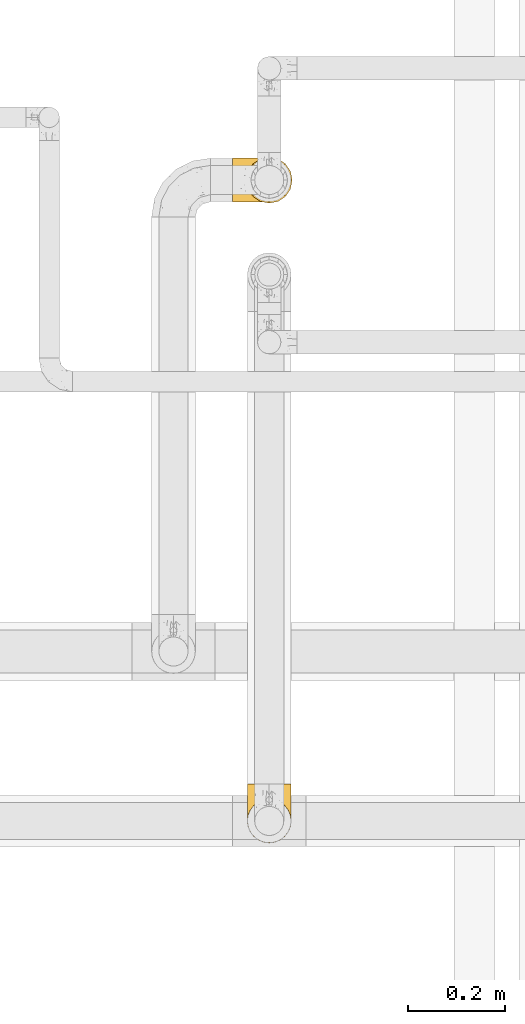
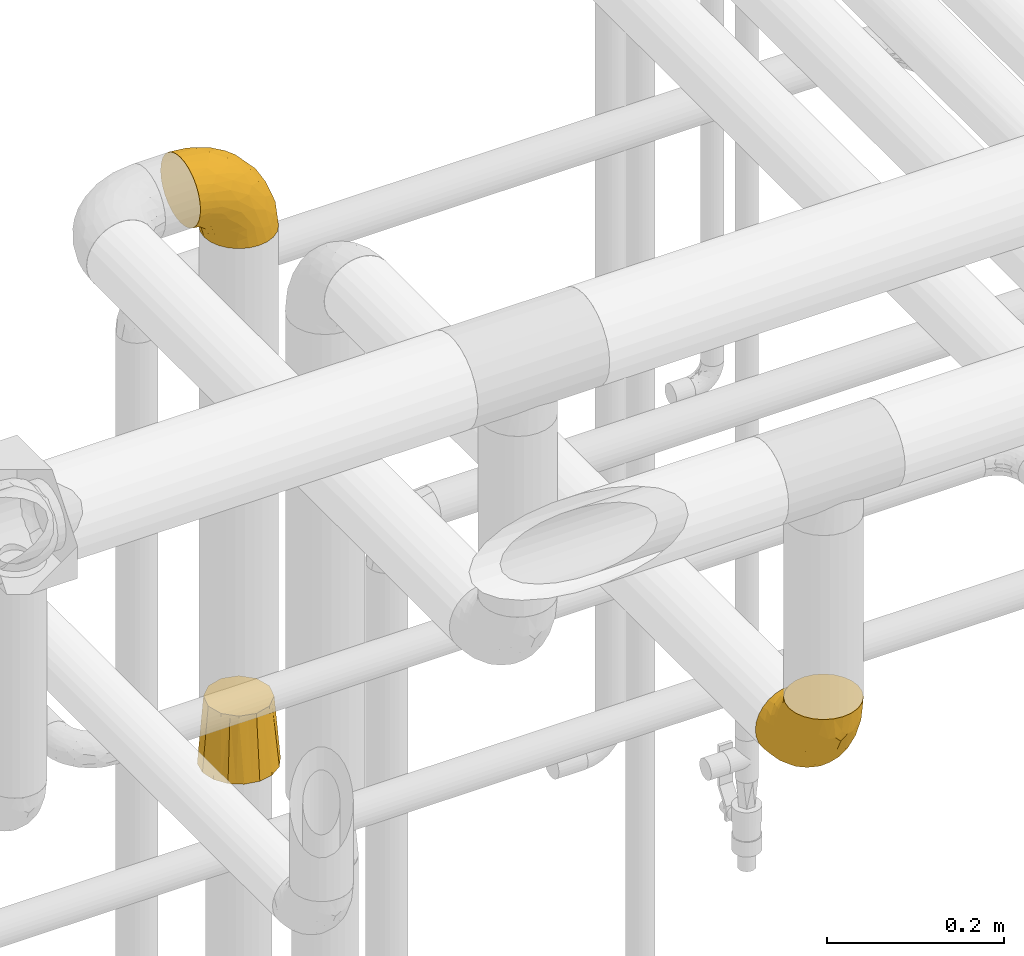
# One storey, part 129 of 827: 3 coverings.
"""IFC2X3 building model written with IfcOpenShell, lengths in millimetres."""

from ifc_helpers import new_model, entity, si_unit, converted_unit, derived_unit, direction, frame, origin, place, context, subcontext, project, spatial, faceted_brep, element, save


model = new_model("IFC2X3")

# Units and contexts
model_context = context("Model", 3, precision=0.01, world=origin(), true_north=direction((6.12303176911189e-17, 1.0)))
body_context = subcontext(model_context, "Body", "Model", "MODEL_VIEW")
ifc_project = project(units=[si_unit("LENGTHUNIT", "METRE", prefix="MILLI"), si_unit("AREAUNIT", "SQUARE_METRE"), si_unit("VOLUMEUNIT", "CUBIC_METRE"), converted_unit("PLANEANGLEUNIT", "DEGREE", entity("IfcRatioMeasure", 0.0174532925199433), si_unit("PLANEANGLEUNIT", "RADIAN"), dimensions=[0, 0, 0, 0, 0, 0, 0]), si_unit("MASSUNIT", "GRAM", prefix="KILO"), derived_unit("MASSDENSITYUNIT", [(si_unit("MASSUNIT", "GRAM", prefix="KILO"), 1), (si_unit("LENGTHUNIT", "METRE"), -3)]), derived_unit("MOMENTOFINERTIAUNIT", [(si_unit("LENGTHUNIT", "METRE"), 4)]), si_unit("TIMEUNIT", "SECOND"), si_unit("FREQUENCYUNIT", "HERTZ"), si_unit("THERMODYNAMICTEMPERATUREUNIT", "DEGREE_CELSIUS"), derived_unit("THERMALTRANSMITTANCEUNIT", [(si_unit("MASSUNIT", "GRAM", prefix="KILO"), 1), (si_unit("THERMODYNAMICTEMPERATUREUNIT", "KELVIN"), -1), (si_unit("TIMEUNIT", "SECOND"), -3)]), derived_unit("VOLUMETRICFLOWRATEUNIT", [(si_unit("LENGTHUNIT", "METRE"), 3), (si_unit("TIMEUNIT", "SECOND"), -1)]), derived_unit("MASSFLOWRATEUNIT", [(si_unit("MASSUNIT", "GRAM", prefix="KILO"), 1), (si_unit("TIMEUNIT", "SECOND"), -1)]), derived_unit("ROTATIONALFREQUENCYUNIT", [(si_unit("TIMEUNIT", "SECOND"), -1)]), si_unit("ELECTRICCURRENTUNIT", "AMPERE"), si_unit("ELECTRICVOLTAGEUNIT", "VOLT"), si_unit("POWERUNIT", "WATT"), si_unit("FORCEUNIT", "NEWTON", prefix="KILO"), si_unit("ILLUMINANCEUNIT", "LUX"), si_unit("LUMINOUSFLUXUNIT", "LUMEN"), si_unit("LUMINOUSINTENSITYUNIT", "CANDELA"), derived_unit("USERDEFINED", [(si_unit("MASSUNIT", "GRAM", prefix="KILO"), -1), (si_unit("LENGTHUNIT", "METRE"), -2), (si_unit("TIMEUNIT", "SECOND"), 3), (si_unit("LUMINOUSFLUXUNIT", "LUMEN"), 1)]), derived_unit("LINEARVELOCITYUNIT", [(si_unit("LENGTHUNIT", "METRE"), 1), (si_unit("TIMEUNIT", "SECOND"), -1)]), si_unit("PRESSUREUNIT", "PASCAL"), derived_unit("USERDEFINED", [(si_unit("LENGTHUNIT", "METRE"), -2), (si_unit("MASSUNIT", "GRAM", prefix="KILO"), 1), (si_unit("TIMEUNIT", "SECOND"), -2)]), derived_unit("LINEARFORCEUNIT", [(si_unit("MASSUNIT", "GRAM", prefix="KILO"), 1), (si_unit("LENGTHUNIT", "METRE"), 1), (si_unit("TIMEUNIT", "SECOND"), -2), (si_unit("LENGTHUNIT", "METRE"), -1)]), derived_unit("PLANARFORCEUNIT", [(si_unit("MASSUNIT", "GRAM", prefix="KILO"), 1), (si_unit("LENGTHUNIT", "METRE"), 1), (si_unit("TIMEUNIT", "SECOND"), -2), (si_unit("LENGTHUNIT", "METRE"), -2)])], contexts=[model_context])

# Site, building, storey
site_placement = place(None, origin())
site = spatial("IfcSite", under=ifc_project, at=site_placement, CompositionType="ELEMENT")
building_placement = place(site_placement, origin())
building = spatial("IfcBuilding", under=site, at=building_placement, CompositionType="ELEMENT")
storey_placement = place(building_placement, frame((0.0, 0.0, 28200.0)))
storey = spatial("IfcBuildingStorey", under=building, at=storey_placement, Name="08", CompositionType="ELEMENT", Elevation=28200.0)

# Coverings
covering_1_placement = place(storey_placement, frame((17844.7, 15675.7, 2322.56)))
element("IfcCovering", 1, at=covering_1_placement, inside=storey, Name=":ADSK_", ObjectType=":ADSK_", PredefinedType="INSULATION", context=body_context, shape_type="Brep", body=[
    faceted_brep([(1.6, 2.73, 87.65), (1.6, 6.07, 97.19), (1.6, 11.45, 105.75), (1.6, 18.6, 112.9), (1.6, 27.16, 118.28), (1.6, 36.7, 121.61), (1.6, 46.75, 122.75), (1.6, 56.8, 121.61), (1.6, 66.34, 118.27), (1.6, 74.9, 112.89), (1.6, 82.05, 105.74), (1.6, 87.43, 97.18), (1.6, 90.76, 87.64), (1.6, 91.9, 77.6), (1.6, 90.76, 67.54), (1.6, 87.42, 58.0), (1.6, 82.04, 49.44), (1.6, 74.89, 42.29), (1.6, 66.33, 36.91), (1.6, 56.79, 33.58), (1.6, 46.75, 32.45), (1.6, 36.69, 33.58), (1.6, 27.15, 36.92), (1.6, 18.59, 42.3), (1.6, 11.44, 49.45), (1.6, 6.06, 58.01), (1.6, 2.73, 67.55), (1.6, 1.6, 77.6), (33.98, 58.43, 1.6), (38.49, 69.32, 1.6), (45.67, 78.67, 1.6), (55.02, 85.85, 1.6), (65.91, 90.36, 1.6), (77.6, 91.9, 1.6), (89.28, 90.36, 1.6), (100.17, 85.85, 1.6), (109.52, 78.67, 1.6), (116.7, 69.32, 1.6), (121.21, 58.43, 1.6), (122.75, 46.75, 1.6), (121.21, 35.06, 1.6), (116.7, 24.17, 1.6), (109.52, 14.82, 1.6), (100.17, 7.64, 1.6), (89.28, 3.13, 1.6), (77.6, 1.6, 1.6), (65.91, 3.13, 1.6), (55.02, 7.64, 1.6), (45.67, 14.82, 1.6), (38.49, 24.17, 1.6), (33.98, 35.06, 1.6), (32.45, 46.75, 1.6), (72.81, 46.75, 99.61), (77.17, 38.29, 95.26), (86.21, 46.75, 86.21), (116.82, 46.75, 39.03), (118.49, 38.96, 30.75), (119.23, 46.75, 23.8), (105.14, 33.86, 60.8), (85.37, 31.42, 85.37), (89.33, 21.63, 73.64), (116.14, 30.84, 31.01), (105.06, 22.16, 49.14), (112.15, 20.56, 23.88), (22.95, 2.29, 82.74), (89.91, 7.18, 43.48), (103.39, 12.6, 29.47), (93.6, 14.0, 56.38), (51.41, 2.81, 72.18), (67.71, 6.65, 72.24), (43.53, 6.11, 87.6), (30.91, 16.62, 107.24), (23.58, 9.76, 101.1), (50.07, 12.46, 95.16), (30.68, 1.6, 71.81), (43.01, 1.6, 63.57), (55.34, 1.6, 55.34), (83.48, 2.46, 23.66), (94.96, 5.91, 20.55), (57.29, 36.97, 107.97), (39.03, 46.75, 116.82), (30.66, 33.09, 117.03), (71.81, 1.6, 30.68), (73.63, 1.6, 21.51), (75.46, 1.6, 12.33), (51.57, 25.62, 106.17), (73.13, 3.14, 52.37), (23.16, 23.92, 114.51), (23.8, 46.75, 119.23), (75.6, 13.58, 78.37), (12.33, 1.6, 75.46), (21.51, 1.6, 73.63), (50.46, 18.5, 101.51), (99.61, 46.75, 72.81), (63.57, 1.6, 43.01), (21.26, 4.96, 92.6), (69.54, 20.84, 91.86), (108.21, 46.75, 55.92), (68.42, 30.52, 99.01), (55.92, 46.75, 108.21), (19.36, 27.29, 32.05), (15.76, 36.89, 30.22), (26.13, 33.6, 23.37), (62.78, 2.54, 28.43), (63.65, 3.27, 16.44), (24.34, 16.85, 37.1), (28.46, 21.91, 28.88), (33.53, 13.5, 33.93), (39.46, 3.96, 50.17), (51.05, 3.52, 40.57), (10.94, 12.17, 47.62), (14.55, 18.93, 39.9), (22.21, 9.34, 47.92), (57.05, 3.12, 34.27), (54.0, 5.67, 24.65), (29.19, 2.51, 62.6), (18.85, 2.53, 66.18), (52.84, 8.35, 11.74), (31.47, 35.39, 13.89), (28.31, 46.75, 17.02), (43.0, 15.1, 15.86), (16.9, 5.27, 57.71), (35.98, 27.43, 9.11), (33.91, 24.89, 18.55), (9.97, 29.71, 34.74), (25.93, 5.07, 54.95), (35.61, 2.88, 57.35), (47.45, 9.69, 22.03), (38.26, 15.51, 24.8), (11.7, 2.27, 69.07), (30.13, 10.03, 42.31), (12.12, 46.75, 29.63), (17.02, 46.75, 28.31), (44.39, 8.83, 30.23), (39.83, 7.16, 40.13), (22.67, 46.75, 22.67), (29.63, 46.75, 12.12), (43.0, 78.39, 15.86), (47.45, 83.8, 22.03), (38.26, 77.97, 24.8), (44.38, 84.66, 30.23), (31.47, 58.1, 13.88), (10.93, 81.31, 47.61), (21.51, 91.9, 73.63), (18.84, 90.96, 66.17), (11.7, 91.22, 69.07), (15.76, 56.59, 30.22), (19.36, 66.18, 32.04), (26.14, 59.87, 23.36), (25.94, 88.42, 54.93), (22.21, 84.13, 47.91), (16.9, 88.22, 57.69), (35.98, 66.06, 9.1), (73.63, 91.9, 21.51), (75.46, 91.9, 12.33), (30.12, 83.44, 42.29), (24.33, 76.62, 37.09), (52.84, 85.14, 11.74), (63.65, 90.22, 16.44), (71.81, 91.9, 30.68), (28.45, 71.55, 28.86), (9.97, 63.77, 34.74), (43.01, 91.9, 63.57), (55.34, 91.9, 55.34), (39.46, 89.53, 50.17), (12.33, 91.9, 75.46), (14.54, 74.55, 39.89), (62.78, 90.95, 28.43), (57.05, 90.37, 34.27), (63.57, 91.9, 43.01), (29.2, 90.98, 62.59), (51.05, 89.97, 40.57), (39.81, 86.32, 40.13), (30.68, 91.9, 71.81), (33.52, 79.97, 33.92), (35.61, 90.61, 57.34), (54.0, 87.82, 24.65), (33.91, 68.6, 18.54), (103.39, 80.89, 29.47), (89.91, 86.31, 43.48), (93.6, 79.49, 56.4), (105.05, 71.33, 49.17), (89.27, 71.88, 73.69), (73.13, 90.35, 52.37), (67.67, 86.85, 72.26), (69.49, 72.67, 91.88), (85.36, 62.08, 85.36), (94.96, 87.58, 20.55), (83.48, 91.03, 23.66), (105.14, 59.62, 60.8), (116.13, 62.65, 31.02), (118.49, 54.53, 30.75), (112.15, 72.93, 23.9), (51.41, 90.68, 72.17), (43.51, 87.39, 87.59), (22.95, 91.2, 82.74), (30.66, 60.41, 117.03), (30.91, 76.88, 107.23), (57.3, 56.53, 107.97), (23.58, 83.74, 101.08), (51.56, 67.88, 106.17), (68.41, 62.99, 99.01), (23.16, 69.58, 114.5), (50.07, 81.04, 95.15), (50.45, 75.0, 101.5), (21.25, 88.53, 92.59), (75.56, 79.93, 78.38), (77.16, 55.21, 95.27)], [[[0, 1, 2, 3, 4, 5, 6, 7, 8, 9, 10, 11, 12, 13, 14, 15, 16, 17, 18, 19, 20, 21, 22, 23, 24, 25, 26, 27]], [[28, 29, 30, 31, 32, 33, 34, 35, 36, 37, 38, 39, 40, 41, 42, 43, 44, 45, 46, 47, 48, 49, 50, 51]], [[52, 53, 54]], [[55, 56, 57]], [[58, 59, 60]], [[61, 62, 63]], [[27, 64, 0]], [[65, 66, 67]], [[41, 40, 61]], [[68, 69, 70]], [[66, 43, 42]], [[63, 42, 41]], [[71, 72, 73]], [[72, 2, 1]], [[68, 74, 75, 76]], [[45, 44, 77]], [[43, 78, 44]], [[79, 80, 81]], [[77, 82, 83, 84, 45]], [[79, 81, 85]], [[71, 2, 72]], [[65, 86, 77]], [[4, 81, 5]], [[66, 65, 78]], [[4, 3, 87]], [[81, 88, 5]], [[63, 66, 42]], [[68, 70, 64]], [[67, 60, 89]], [[71, 3, 2]], [[64, 27, 90, 91, 74]], [[92, 71, 73]], [[40, 57, 56]], [[59, 93, 54]], [[86, 76, 94, 82]], [[1, 0, 95]], [[58, 62, 61]], [[60, 96, 89]], [[85, 81, 87]], [[56, 97, 58]], [[65, 67, 69]], [[87, 81, 4]], [[67, 89, 69]], [[61, 63, 41]], [[95, 72, 1]], [[73, 72, 70]], [[69, 73, 70]], [[73, 89, 96]], [[3, 71, 87]], [[85, 87, 71]], [[58, 61, 56]], [[59, 58, 93]], [[76, 86, 68]], [[69, 89, 73]], [[68, 86, 69]], [[65, 69, 86]], [[68, 64, 74]], [[95, 64, 70]], [[98, 79, 85]], [[79, 52, 99, 80]], [[66, 62, 67]], [[62, 58, 60]], [[62, 60, 67]], [[59, 98, 96]], [[59, 96, 60]], [[96, 85, 92]], [[88, 81, 80]], [[88, 6, 5]], [[66, 63, 62]], [[64, 95, 0]], [[72, 95, 70]], [[77, 44, 78]], [[86, 82, 77]], [[40, 39, 57]], [[96, 98, 85]], [[40, 56, 61]], [[66, 78, 43]], [[77, 78, 65]], [[79, 98, 53]], [[96, 92, 73]], [[85, 71, 92]], [[97, 56, 55]], [[97, 93, 58]], [[53, 98, 59]], [[54, 53, 59]], [[79, 53, 52]], [[100, 101, 102]], [[46, 45, 84, 83]], [[103, 104, 82]], [[82, 104, 83]], [[105, 106, 107]], [[108, 109, 76]], [[110, 111, 112]], [[103, 113, 114]], [[115, 74, 116]], [[48, 47, 117]], [[118, 102, 119]], [[49, 48, 120]], [[74, 91, 116]], [[116, 121, 115]], [[49, 122, 50]], [[123, 106, 102]], [[124, 111, 22]], [[125, 126, 115]], [[23, 22, 111]], [[24, 110, 121]], [[120, 127, 128]], [[90, 26, 129]], [[27, 26, 90]], [[121, 125, 115]], [[24, 121, 25]], [[130, 105, 107]], [[129, 25, 116]], [[21, 20, 131]], [[120, 123, 122]], [[112, 105, 130]], [[50, 118, 51]], [[21, 124, 22]], [[101, 131, 132]], [[117, 120, 48]], [[24, 23, 110]], [[127, 114, 133]], [[75, 108, 76]], [[107, 134, 130]], [[133, 114, 113]], [[129, 116, 91]], [[25, 121, 116]], [[121, 112, 125]], [[75, 74, 115]], [[101, 135, 102]], [[131, 101, 21]], [[101, 100, 124]], [[128, 127, 133]], [[119, 136, 51, 118]], [[104, 47, 46]], [[83, 104, 46]], [[117, 104, 114]], [[101, 124, 21]], [[111, 124, 100]], [[102, 118, 123]], [[133, 134, 107]], [[111, 110, 23]], [[114, 104, 103]], [[94, 76, 109]], [[121, 110, 112]], [[122, 118, 50]], [[134, 109, 108]], [[133, 107, 128]], [[112, 108, 125]], [[126, 125, 108]], [[108, 75, 126]], [[75, 115, 126]], [[109, 134, 133]], [[130, 108, 112]], [[108, 130, 134]], [[105, 112, 111]], [[111, 100, 105]], [[106, 105, 100]], [[102, 106, 100]], [[128, 106, 123]], [[90, 129, 91]], [[25, 129, 26]], [[104, 117, 47]], [[117, 114, 127]], [[82, 94, 103]], [[113, 94, 109]], [[94, 113, 103]], [[133, 113, 109]], [[106, 128, 107]], [[123, 120, 128]], [[120, 122, 49]], [[118, 122, 123]], [[135, 101, 132]], [[135, 119, 102]], [[117, 127, 120]], [[30, 29, 137]], [[138, 139, 140]], [[51, 136, 119, 141]], [[142, 17, 16]], [[143, 144, 145]], [[146, 147, 148]], [[149, 150, 151]], [[152, 29, 28]], [[33, 32, 153, 154]], [[150, 155, 156]], [[157, 31, 30]], [[153, 158, 159]], [[29, 152, 137]], [[148, 141, 119]], [[156, 160, 147]], [[148, 135, 146]], [[137, 138, 157]], [[19, 161, 146]], [[162, 163, 164]], [[14, 13, 165]], [[153, 32, 158]], [[147, 161, 166]], [[18, 17, 166]], [[167, 168, 169]], [[166, 150, 156]], [[151, 150, 142]], [[151, 170, 149]], [[151, 16, 15]], [[171, 140, 172]], [[165, 143, 145]], [[173, 170, 144]], [[142, 166, 17]], [[19, 131, 20]], [[144, 170, 151]], [[18, 161, 19]], [[173, 144, 143]], [[140, 139, 174]], [[171, 164, 163]], [[164, 172, 155]], [[151, 15, 144]], [[145, 15, 14]], [[173, 162, 170]], [[149, 175, 164]], [[19, 146, 131]], [[132, 131, 146]], [[160, 148, 147]], [[159, 158, 167]], [[135, 132, 146]], [[158, 32, 31]], [[157, 158, 31]], [[167, 158, 176]], [[166, 161, 18]], [[146, 161, 147]], [[148, 177, 141]], [[171, 168, 140]], [[171, 163, 169]], [[151, 142, 16]], [[166, 142, 150]], [[152, 141, 177]], [[51, 141, 28]], [[138, 140, 176]], [[172, 140, 174]], [[175, 149, 170]], [[164, 150, 149]], [[170, 162, 175]], [[162, 164, 175]], [[155, 172, 174]], [[171, 172, 164]], [[155, 174, 156]], [[164, 155, 150]], [[160, 156, 174]], [[147, 166, 156]], [[139, 160, 174]], [[148, 160, 177]], [[15, 145, 144]], [[165, 145, 14]], [[137, 157, 30]], [[158, 157, 176]], [[168, 167, 176]], [[169, 159, 167]], [[140, 168, 176]], [[169, 168, 171]], [[137, 177, 139]], [[160, 139, 177]], [[141, 152, 28]], [[137, 152, 177]], [[148, 119, 135]], [[157, 138, 176]], [[139, 138, 137]], [[178, 179, 180]], [[181, 180, 182]], [[179, 183, 184]], [[185, 186, 182]], [[187, 188, 179]], [[188, 33, 154, 153, 159]], [[181, 189, 190]], [[35, 34, 187]], [[191, 38, 190]], [[192, 178, 181]], [[179, 184, 180]], [[192, 190, 37]], [[37, 190, 38]], [[36, 35, 178]], [[54, 93, 186]], [[35, 187, 178]], [[193, 194, 184]], [[195, 173, 143, 165, 13]], [[195, 193, 173]], [[193, 163, 162, 173]], [[13, 12, 195]], [[8, 7, 196]], [[9, 197, 10]], [[198, 80, 99, 52]], [[196, 7, 88]], [[197, 199, 10]], [[182, 189, 181]], [[200, 198, 201]], [[200, 196, 198]], [[9, 8, 202]], [[194, 199, 203]], [[192, 37, 36]], [[80, 196, 88]], [[183, 159, 169, 163]], [[188, 34, 33]], [[202, 200, 197]], [[185, 203, 204]], [[202, 8, 196]], [[10, 199, 11]], [[12, 11, 205]], [[38, 191, 57]], [[189, 97, 191]], [[203, 199, 197]], [[205, 199, 194]], [[204, 203, 197]], [[184, 203, 206]], [[200, 202, 196]], [[197, 9, 202]], [[207, 54, 186]], [[97, 55, 191]], [[194, 203, 184]], [[183, 163, 193]], [[184, 206, 180]], [[183, 193, 184]], [[205, 195, 12]], [[193, 195, 194]], [[80, 198, 196]], [[207, 186, 201]], [[182, 180, 206]], [[181, 178, 180]], [[185, 182, 206]], [[182, 186, 189]], [[203, 185, 206]], [[185, 200, 201]], [[7, 6, 88]], [[178, 192, 36]], [[190, 192, 181]], [[199, 205, 11]], [[195, 205, 194]], [[159, 183, 188]], [[179, 188, 183]], [[57, 191, 55]], [[57, 39, 38]], [[189, 191, 190]], [[188, 187, 34]], [[178, 187, 179]], [[186, 93, 189]], [[197, 200, 204]], [[185, 204, 200]], [[189, 93, 97]], [[207, 198, 52]], [[185, 201, 186]], [[198, 207, 201]], [[54, 207, 52]]]),
])
covering_2_placement = place(storey_placement, frame((17873.2, 15673.14, 1586.32)))
element("IfcCovering", 2, at=covering_2_placement, inside=storey, Name=":ADSK_", ObjectType=":ADSK_", PredefinedType="INSULATION", context=body_context, shape_type="Brep", body=[
    faceted_brep([(29.1, 14.45, 89.0), (39.1, 11.77, 89.0), (49.1, 9.1, 89.0), (59.1, 11.77, 89.0), (69.1, 14.45, 89.0), (76.42, 21.77, 89.0), (83.74, 29.1, 89.0), (86.42, 39.1, 89.0), (89.1, 49.1, 89.0), (86.42, 59.1, 89.0), (83.74, 69.1, 89.0), (76.42, 76.42, 89.0), (69.1, 83.74, 89.0), (59.1, 86.42, 89.0), (49.1, 89.1, 89.0), (39.1, 86.42, 89.0), (29.1, 83.74, 89.0), (21.77, 76.42, 89.0), (14.45, 69.1, 89.0), (11.77, 59.1, 89.0), (9.1, 49.1, 89.0), (11.77, 39.1, 89.0), (14.45, 29.1, 89.0), (21.77, 21.77, 89.0), (10.36, 74.98, 0.0), (15.51, 82.68, 0.0), (23.21, 87.83, 0.0), (30.92, 92.98, 0.0), (40.01, 94.79, 0.0), (49.1, 96.6, 0.0), (58.18, 94.79, 0.0), (67.27, 92.98, 0.0), (74.98, 87.83, 0.0), (82.68, 82.68, 0.0), (87.83, 74.98, 0.0), (92.98, 67.27, 0.0), (94.79, 58.18, 0.0), (96.6, 49.1, 0.0), (94.79, 40.01, 0.0), (92.98, 30.92, 0.0), (87.83, 23.21, 0.0), (82.68, 15.51, 0.0), (74.98, 10.36, 0.0), (67.27, 5.21, 0.0), (58.18, 3.4, 0.0), (49.1, 1.6, 0.0), (40.01, 3.4, 0.0), (30.92, 5.21, 0.0), (23.21, 10.36, 0.0), (15.51, 15.51, 0.0), (10.36, 23.21, 0.0), (5.21, 30.92, 0.0), (3.4, 40.01, 0.0), (1.6, 49.1, 0.0), (3.4, 58.18, 0.0), (5.21, 67.27, 0.0)], [[[0, 1, 2, 3, 4, 5, 6, 7, 8, 9, 10, 11, 12, 13, 14, 15, 16, 17, 18, 19, 20, 21, 22, 23]], [[24, 25, 26, 27, 28, 29, 30, 31, 32, 33, 34, 35, 36, 37, 38, 39, 40, 41, 42, 43, 44, 45, 46, 47, 48, 49, 50, 51, 52, 53, 54, 55]], [[38, 37, 8]], [[40, 39, 6]], [[40, 6, 5]], [[4, 42, 5]], [[40, 5, 41]], [[44, 2, 45]], [[8, 7, 38]], [[42, 41, 5]], [[2, 44, 3]], [[7, 6, 39]], [[7, 39, 38]], [[43, 4, 3]], [[44, 43, 3]], [[4, 43, 42]], [[30, 29, 14]], [[32, 31, 12]], [[32, 12, 11]], [[10, 34, 11]], [[32, 11, 33]], [[36, 8, 37]], [[14, 13, 30]], [[34, 33, 11]], [[8, 36, 9]], [[13, 12, 31]], [[13, 31, 30]], [[35, 10, 9]], [[36, 35, 9]], [[10, 35, 34]], [[54, 53, 20]], [[24, 55, 18]], [[24, 18, 17]], [[16, 26, 17]], [[24, 17, 25]], [[28, 14, 29]], [[20, 19, 54]], [[26, 25, 17]], [[14, 28, 15]], [[19, 18, 55]], [[19, 55, 54]], [[27, 16, 15]], [[28, 27, 15]], [[16, 27, 26]], [[46, 45, 2]], [[48, 47, 0]], [[48, 0, 23]], [[22, 50, 23]], [[48, 23, 49]], [[52, 20, 53]], [[2, 1, 46]], [[50, 49, 23]], [[20, 52, 21]], [[1, 0, 47]], [[1, 47, 46]], [[51, 22, 21]], [[52, 51, 21]], [[22, 51, 50]]]),
])
covering_3_placement = place(storey_placement, frame((17875.55, 14353.25, 2353.25)))
element("IfcCovering", 3, at=covering_3_placement, inside=storey, Name=":ADSK_", ObjectType=":ADSK_", PredefinedType="INSULATION", context=body_context, shape_type="Brep", body=[
    faceted_brep([(90.76, 122.75, 36.69), (87.42, 122.75, 27.15), (82.04, 122.75, 18.59), (74.89, 122.75, 11.44), (66.33, 122.75, 6.06), (56.79, 122.75, 2.73), (46.75, 122.75, 1.6), (36.69, 122.75, 2.73), (27.15, 122.75, 6.07), (18.59, 122.75, 11.45), (11.44, 122.75, 18.6), (6.06, 122.75, 27.16), (2.73, 122.75, 36.7), (1.6, 122.75, 46.75), (2.73, 122.75, 56.8), (6.07, 122.75, 66.34), (11.45, 122.75, 74.9), (18.6, 122.75, 82.05), (27.16, 122.75, 87.43), (36.7, 122.75, 90.76), (46.75, 122.75, 91.9), (56.8, 122.75, 90.76), (66.34, 122.75, 87.42), (74.9, 122.75, 82.04), (82.05, 122.75, 74.89), (87.43, 122.75, 66.33), (90.76, 122.75, 56.79), (91.9, 122.75, 46.75), (35.06, 90.36, 122.75), (24.17, 85.85, 122.75), (14.82, 78.67, 122.75), (7.64, 69.32, 122.75), (3.13, 58.43, 122.75), (1.6, 46.75, 122.75), (3.13, 35.06, 122.75), (7.64, 24.17, 122.75), (14.82, 14.82, 122.75), (24.17, 7.64, 122.75), (35.06, 3.13, 122.75), (46.75, 1.6, 122.75), (58.43, 3.13, 122.75), (69.32, 7.64, 122.75), (78.67, 14.82, 122.75), (85.85, 24.17, 122.75), (90.36, 35.06, 122.75), (91.9, 46.75, 122.75), (90.36, 58.43, 122.75), (85.85, 69.32, 122.75), (78.67, 78.67, 122.75), (69.32, 85.85, 122.75), (58.43, 90.36, 122.75), (46.75, 91.9, 122.75), (46.75, 51.54, 24.73), (55.2, 47.17, 29.08), (46.75, 38.13, 38.13), (46.75, 7.52, 85.31), (54.53, 5.85, 93.59), (46.75, 5.11, 100.54), (59.63, 19.2, 63.54), (62.07, 38.98, 38.98), (71.86, 35.02, 50.71), (62.65, 8.21, 93.33), (71.33, 19.28, 75.2), (72.93, 12.19, 100.46), (91.2, 101.39, 41.6), (86.31, 34.43, 80.86), (80.89, 20.95, 94.87), (79.49, 30.74, 67.96), (90.68, 72.93, 52.16), (86.84, 56.64, 52.1), (87.38, 80.81, 36.74), (76.87, 93.43, 17.11), (83.73, 100.76, 23.24), (81.03, 74.27, 29.18), (91.9, 93.66, 52.53), (91.9, 81.33, 60.77), (91.9, 69.01, 69.01), (91.03, 40.87, 100.68), (87.58, 29.38, 103.79), (56.52, 67.05, 16.37), (46.75, 85.31, 7.52), (60.4, 93.68, 7.31), (91.9, 52.53, 93.66), (91.9, 50.71, 102.83), (91.9, 48.88, 112.01), (67.87, 72.77, 18.17), (90.35, 51.21, 71.97), (69.57, 101.18, 9.83), (46.75, 100.54, 5.11), (79.91, 48.74, 45.97), (91.9, 112.01, 48.88), (91.9, 102.83, 50.71), (74.99, 73.88, 22.83), (46.75, 24.73, 51.54), (91.9, 60.77, 81.33), (88.53, 103.08, 31.74), (72.65, 54.8, 32.48), (46.75, 16.13, 68.42), (62.97, 55.92, 25.33), (46.75, 68.42, 16.13), (66.2, 104.98, 92.29), (56.6, 108.58, 94.12), (59.89, 98.21, 100.97), (90.95, 61.56, 95.91), (90.22, 60.69, 107.9), (76.64, 100.0, 87.24), (71.58, 95.88, 95.46), (79.99, 90.81, 90.41), (89.54, 84.88, 74.17), (89.97, 73.29, 83.77), (81.32, 113.4, 76.72), (74.56, 109.8, 84.44), (84.15, 102.13, 76.42), (90.37, 67.29, 90.07), (87.82, 70.34, 99.69), (90.98, 95.15, 61.74), (90.96, 105.49, 58.16), (85.14, 71.5, 112.6), (58.11, 92.87, 110.45), (46.75, 96.03, 107.32), (78.39, 81.34, 108.48), (88.22, 107.44, 66.63), (66.06, 88.36, 115.23), (68.6, 90.43, 105.79), (63.78, 114.37, 89.6), (88.42, 98.41, 69.39), (90.61, 88.73, 66.99), (83.8, 76.89, 102.31), (77.98, 86.08, 99.54), (91.22, 112.64, 55.27), (83.46, 94.21, 82.03), (46.75, 112.22, 94.71), (46.75, 107.32, 96.03), (84.66, 79.95, 94.11), (86.33, 84.51, 84.21), (46.75, 101.67, 101.67), (46.75, 94.71, 112.22), (15.1, 81.34, 108.48), (9.69, 76.89, 102.31), (15.52, 86.08, 99.54), (8.83, 79.96, 94.11), (35.39, 92.87, 110.46), (12.18, 113.41, 76.74), (1.6, 102.83, 50.71), (2.53, 105.5, 58.17), (2.27, 112.64, 55.27), (36.9, 108.58, 94.12), (27.31, 104.98, 92.3), (33.62, 98.2, 100.98), (5.07, 98.4, 69.41), (9.36, 102.13, 76.44), (5.27, 107.44, 66.65), (27.43, 88.36, 115.24), (1.6, 50.71, 102.83), (1.6, 48.88, 112.01), (10.05, 94.22, 82.05), (16.87, 100.01, 87.25), (8.35, 71.5, 112.6), (3.27, 60.69, 107.9), (1.6, 52.53, 93.66), (21.94, 95.89, 95.48), (29.72, 114.37, 89.6), (1.6, 81.33, 60.77), (1.6, 69.01, 69.01), (3.96, 84.88, 74.17), (1.6, 112.01, 48.88), (18.95, 109.8, 84.45), (2.54, 61.56, 95.91), (3.12, 67.29, 90.07), (1.6, 60.77, 81.33), (2.51, 95.14, 61.75), (3.52, 73.29, 83.77), (7.17, 84.53, 84.21), (1.6, 93.66, 52.53), (13.52, 90.82, 90.42), (2.88, 88.73, 67.0), (5.67, 70.34, 99.69), (24.89, 90.43, 105.8), (12.6, 20.95, 94.87), (7.18, 34.43, 80.86), (14.0, 30.74, 67.95), (22.16, 19.29, 75.17), (21.61, 35.07, 50.65), (3.14, 51.21, 71.97), (6.65, 56.67, 52.08), (20.82, 54.85, 32.46), (31.41, 38.98, 38.98), (5.91, 29.38, 103.79), (2.46, 40.87, 100.68), (33.87, 19.2, 63.54), (30.84, 8.21, 93.32), (38.96, 5.85, 93.59), (20.56, 12.19, 100.44), (2.81, 72.93, 52.17), (6.1, 80.83, 36.75), (2.29, 101.39, 41.61), (33.08, 93.69, 7.31), (16.61, 93.43, 17.12), (36.96, 67.04, 16.37), (9.75, 100.76, 23.26), (25.61, 72.78, 18.17), (30.5, 55.93, 25.33), (23.91, 101.18, 9.84), (12.45, 74.27, 29.19), (18.49, 73.89, 22.84), (4.96, 103.09, 31.75), (13.56, 48.78, 45.96), (38.28, 47.19, 29.07)], [[[0, 1, 2, 3, 4, 5, 6, 7, 8, 9, 10, 11, 12, 13, 14, 15, 16, 17, 18, 19, 20, 21, 22, 23, 24, 25, 26, 27]], [[28, 29, 30, 31, 32, 33, 34, 35, 36, 37, 38, 39, 40, 41, 42, 43, 44, 45, 46, 47, 48, 49, 50, 51]], [[52, 53, 54]], [[55, 56, 57]], [[58, 59, 60]], [[61, 62, 63]], [[27, 64, 0]], [[65, 66, 67]], [[41, 40, 61]], [[68, 69, 70]], [[66, 43, 42]], [[63, 42, 41]], [[71, 72, 73]], [[72, 2, 1]], [[68, 74, 75, 76]], [[45, 44, 77]], [[43, 78, 44]], [[79, 80, 81]], [[77, 82, 83, 84, 45]], [[79, 81, 85]], [[71, 2, 72]], [[65, 86, 77]], [[4, 81, 5]], [[66, 65, 78]], [[4, 3, 87]], [[81, 88, 5]], [[63, 66, 42]], [[68, 70, 64]], [[67, 60, 89]], [[71, 3, 2]], [[64, 27, 90, 91, 74]], [[92, 71, 73]], [[40, 57, 56]], [[59, 93, 54]], [[86, 76, 94, 82]], [[1, 0, 95]], [[58, 62, 61]], [[60, 96, 89]], [[85, 81, 87]], [[56, 97, 58]], [[65, 67, 69]], [[87, 81, 4]], [[67, 89, 69]], [[61, 63, 41]], [[95, 72, 1]], [[73, 72, 70]], [[69, 73, 70]], [[73, 89, 96]], [[3, 71, 87]], [[85, 87, 71]], [[58, 61, 56]], [[59, 58, 93]], [[76, 86, 68]], [[69, 89, 73]], [[68, 86, 69]], [[65, 69, 86]], [[68, 64, 74]], [[95, 64, 70]], [[98, 79, 85]], [[79, 52, 99, 80]], [[66, 62, 67]], [[62, 58, 60]], [[62, 60, 67]], [[59, 98, 96]], [[59, 96, 60]], [[96, 85, 92]], [[88, 81, 80]], [[88, 6, 5]], [[66, 63, 62]], [[64, 95, 0]], [[72, 95, 70]], [[77, 44, 78]], [[86, 82, 77]], [[40, 39, 57]], [[96, 98, 85]], [[40, 56, 61]], [[66, 78, 43]], [[77, 78, 65]], [[79, 98, 53]], [[96, 92, 73]], [[85, 71, 92]], [[97, 56, 55]], [[97, 93, 58]], [[53, 98, 59]], [[54, 53, 59]], [[79, 53, 52]], [[100, 101, 102]], [[46, 45, 84, 83]], [[103, 104, 82]], [[82, 104, 83]], [[105, 106, 107]], [[108, 109, 76]], [[110, 111, 112]], [[103, 113, 114]], [[115, 74, 116]], [[48, 47, 117]], [[118, 102, 119]], [[49, 48, 120]], [[74, 91, 116]], [[116, 121, 115]], [[49, 122, 50]], [[123, 106, 102]], [[124, 111, 22]], [[125, 126, 115]], [[23, 22, 111]], [[24, 110, 121]], [[120, 127, 128]], [[90, 26, 129]], [[27, 26, 90]], [[121, 125, 115]], [[24, 121, 25]], [[130, 105, 107]], [[129, 25, 116]], [[21, 20, 131]], [[120, 123, 122]], [[112, 105, 130]], [[50, 118, 51]], [[21, 124, 22]], [[101, 131, 132]], [[117, 120, 48]], [[24, 23, 110]], [[127, 114, 133]], [[75, 108, 76]], [[107, 134, 130]], [[133, 114, 113]], [[129, 116, 91]], [[25, 121, 116]], [[121, 112, 125]], [[75, 74, 115]], [[101, 135, 102]], [[131, 101, 21]], [[101, 100, 124]], [[128, 127, 133]], [[119, 136, 51, 118]], [[104, 47, 46]], [[83, 104, 46]], [[117, 104, 114]], [[101, 124, 21]], [[111, 124, 100]], [[102, 118, 123]], [[133, 134, 107]], [[111, 110, 23]], [[114, 104, 103]], [[94, 76, 109]], [[121, 110, 112]], [[122, 118, 50]], [[134, 109, 108]], [[133, 107, 128]], [[112, 108, 125]], [[126, 125, 108]], [[108, 75, 126]], [[75, 115, 126]], [[109, 134, 133]], [[130, 108, 112]], [[108, 130, 134]], [[105, 112, 111]], [[111, 100, 105]], [[106, 105, 100]], [[102, 106, 100]], [[128, 106, 123]], [[90, 129, 91]], [[25, 129, 26]], [[104, 117, 47]], [[117, 114, 127]], [[82, 94, 103]], [[113, 94, 109]], [[94, 113, 103]], [[133, 113, 109]], [[106, 128, 107]], [[123, 120, 128]], [[120, 122, 49]], [[118, 122, 123]], [[135, 101, 132]], [[135, 119, 102]], [[117, 127, 120]], [[30, 29, 137]], [[138, 139, 140]], [[51, 136, 119, 141]], [[142, 17, 16]], [[143, 144, 145]], [[146, 147, 148]], [[149, 150, 151]], [[152, 29, 28]], [[33, 32, 153, 154]], [[150, 155, 156]], [[157, 31, 30]], [[153, 158, 159]], [[29, 152, 137]], [[148, 141, 119]], [[156, 160, 147]], [[148, 135, 146]], [[137, 138, 157]], [[19, 161, 146]], [[162, 163, 164]], [[14, 13, 165]], [[153, 32, 158]], [[147, 161, 166]], [[18, 17, 166]], [[167, 168, 169]], [[166, 150, 156]], [[151, 150, 142]], [[151, 170, 149]], [[151, 16, 15]], [[171, 140, 172]], [[165, 143, 145]], [[173, 170, 144]], [[142, 166, 17]], [[19, 131, 20]], [[144, 170, 151]], [[18, 161, 19]], [[173, 144, 143]], [[140, 139, 174]], [[171, 164, 163]], [[164, 172, 155]], [[151, 15, 144]], [[145, 15, 14]], [[173, 162, 170]], [[149, 175, 164]], [[19, 146, 131]], [[132, 131, 146]], [[160, 148, 147]], [[159, 158, 167]], [[135, 132, 146]], [[158, 32, 31]], [[157, 158, 31]], [[167, 158, 176]], [[166, 161, 18]], [[146, 161, 147]], [[148, 177, 141]], [[171, 168, 140]], [[171, 163, 169]], [[151, 142, 16]], [[166, 142, 150]], [[152, 141, 177]], [[51, 141, 28]], [[138, 140, 176]], [[172, 140, 174]], [[175, 149, 170]], [[164, 150, 149]], [[170, 162, 175]], [[162, 164, 175]], [[155, 172, 174]], [[171, 172, 164]], [[155, 174, 156]], [[164, 155, 150]], [[160, 156, 174]], [[147, 166, 156]], [[139, 160, 174]], [[148, 160, 177]], [[15, 145, 144]], [[165, 145, 14]], [[137, 157, 30]], [[158, 157, 176]], [[168, 167, 176]], [[169, 159, 167]], [[140, 168, 176]], [[169, 168, 171]], [[137, 177, 139]], [[160, 139, 177]], [[141, 152, 28]], [[137, 152, 177]], [[148, 119, 135]], [[157, 138, 176]], [[139, 138, 137]], [[178, 179, 180]], [[181, 180, 182]], [[179, 183, 184]], [[185, 186, 182]], [[187, 188, 179]], [[188, 33, 154, 153, 159]], [[181, 189, 190]], [[35, 34, 187]], [[191, 38, 190]], [[192, 178, 181]], [[179, 184, 180]], [[192, 190, 37]], [[37, 190, 38]], [[36, 35, 178]], [[54, 93, 186]], [[35, 187, 178]], [[193, 194, 184]], [[195, 173, 143, 165, 13]], [[195, 193, 173]], [[193, 163, 162, 173]], [[13, 12, 195]], [[8, 7, 196]], [[9, 197, 10]], [[198, 80, 99, 52]], [[196, 7, 88]], [[197, 199, 10]], [[182, 189, 181]], [[200, 198, 201]], [[200, 196, 198]], [[9, 8, 202]], [[194, 199, 203]], [[192, 37, 36]], [[80, 196, 88]], [[183, 159, 169, 163]], [[188, 34, 33]], [[202, 200, 197]], [[185, 203, 204]], [[202, 8, 196]], [[10, 199, 11]], [[12, 11, 205]], [[38, 191, 57]], [[189, 97, 191]], [[203, 199, 197]], [[205, 199, 194]], [[204, 203, 197]], [[184, 203, 206]], [[200, 202, 196]], [[197, 9, 202]], [[207, 54, 186]], [[97, 55, 191]], [[194, 203, 184]], [[183, 163, 193]], [[184, 206, 180]], [[183, 193, 184]], [[205, 195, 12]], [[193, 195, 194]], [[80, 198, 196]], [[207, 186, 201]], [[182, 180, 206]], [[181, 178, 180]], [[185, 182, 206]], [[182, 186, 189]], [[203, 185, 206]], [[185, 200, 201]], [[7, 6, 88]], [[178, 192, 36]], [[190, 192, 181]], [[199, 205, 11]], [[195, 205, 194]], [[159, 183, 188]], [[179, 188, 183]], [[57, 191, 55]], [[57, 39, 38]], [[189, 191, 190]], [[188, 187, 34]], [[178, 187, 179]], [[186, 93, 189]], [[197, 200, 204]], [[185, 204, 200]], [[189, 93, 97]], [[207, 198, 52]], [[185, 201, 186]], [[198, 207, 201]], [[54, 207, 52]]]),
])

save(model, "model.ifc")
